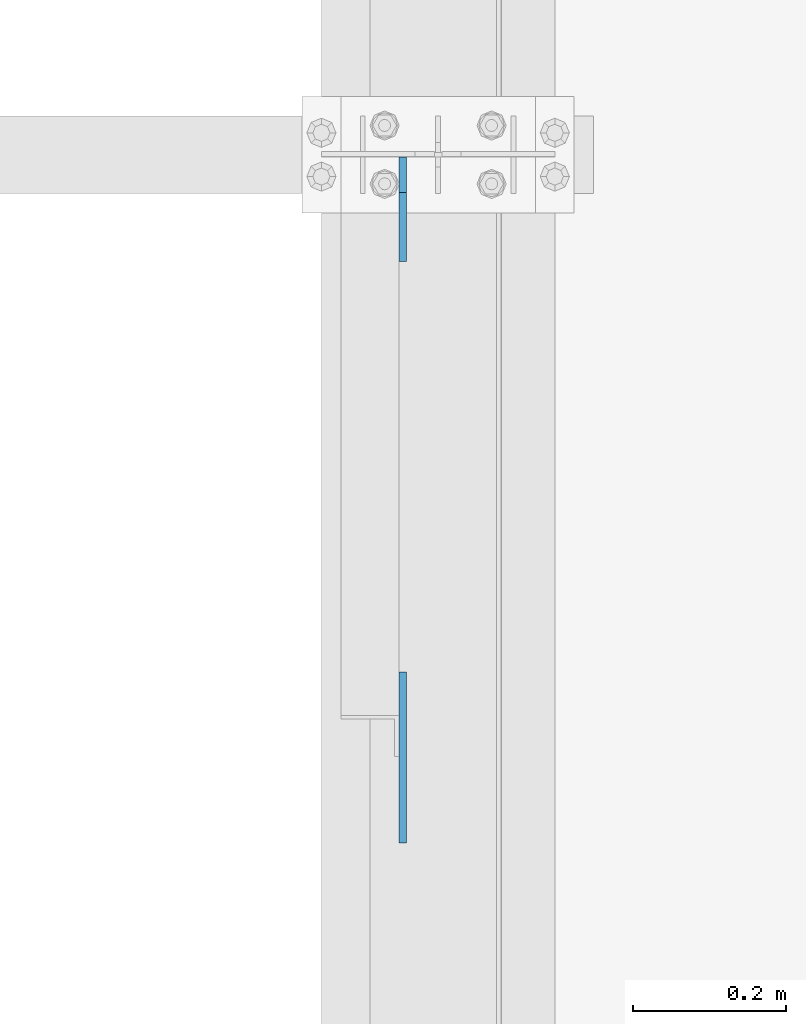
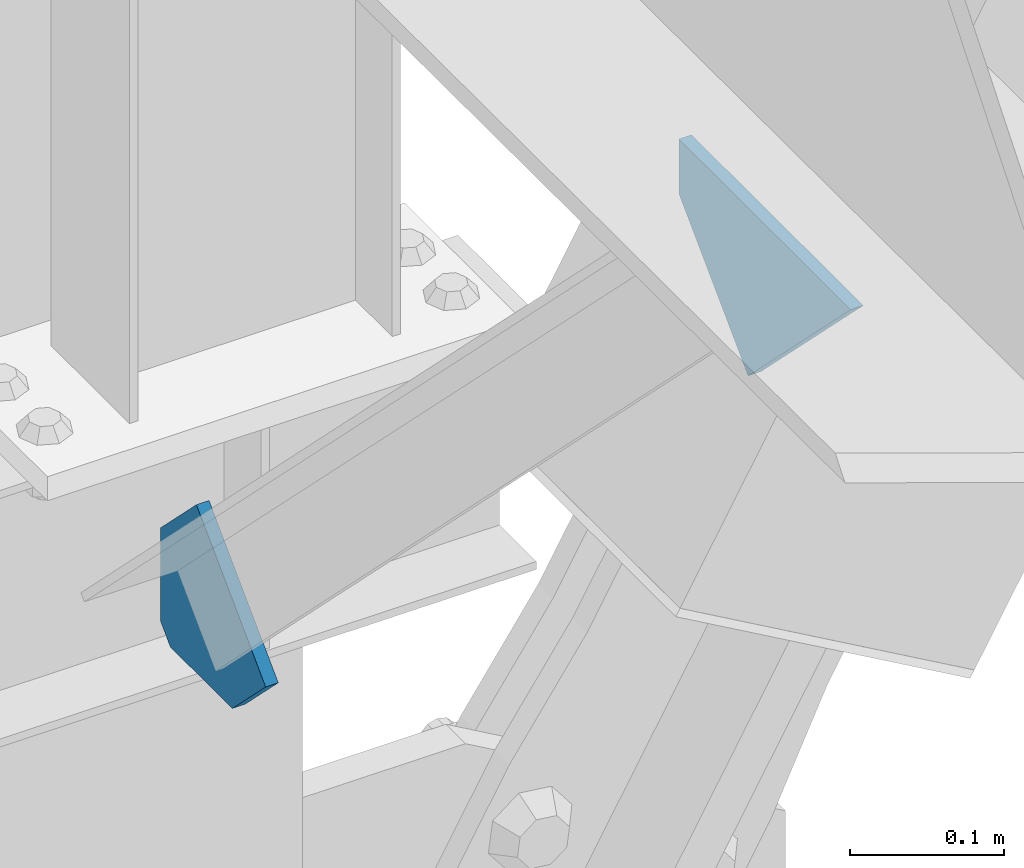
# One storey, part 3378 of 3843: 2 plates, 2 elements without a shape of their own.
"""IFC2X3 building model written with IfcOpenShell, lengths in millimetres."""

import ifcopenshell
import ifcopenshell.guid

model = None  # the IFC model being written
_history = None  # IfcOwnerHistory: only IFC2X3 demands one
_inside = {}  # id of a spatial element -> (the spatial element, [elements in it])
_under = {}  # id of a project, library or spatial element -> (it, [spatial elements below it])
_declared = {}  # id of a project -> (the project, [libraries it declares])
_typed = {}  # id of a type object -> (the type object, [elements of that type])
_made_of = {}  # id of a material, layer set ... -> (it, [elements and type objects made of it])


def new_model(schema):
    """Start an empty IFC model of exactly this schema.

    Asked for "IFC4X3", IfcOpenShell would pick the latest addendum, in which some entities
    have other attributes; the version numbers below select the first issue.
    IFC2X3 requires an IfcOwnerHistory on every rooted entity: one is made here for all.
    """
    global model, _history
    if schema == "IFC4X3":
        model = ifcopenshell.file(schema_version=(4, 3, 0, 0))
    else:
        model = ifcopenshell.file(schema=schema)
    _inside.clear()
    _under.clear()
    _declared.clear()
    _typed.clear()
    _made_of.clear()
    _history = None
    if model.schema == "IFC2X3":
        org = make("IfcOrganization", Name="unknown")
        user = make(
            "IfcPersonAndOrganization",
            ThePerson=make("IfcPerson", FamilyName="unknown"),
            TheOrganization=org,
        )
        app = make(
            "IfcApplication",
            ApplicationDeveloper=org,
            Version="unknown",
            ApplicationFullName="unknown",
            ApplicationIdentifier="unknown",
        )
        _history = make(
            "IfcOwnerHistory",
            OwningUser=user,
            OwningApplication=app,
            ChangeAction="ADDED",
            CreationDate=0,
        )
    return model


def make(cls, **values):
    """One entity of the class cls with the attributes given. An attribute that is None is left unset."""
    return model.create_entity(
        cls, **{name: value for name, value in values.items() if value is not None}
    )


def rooted(cls, **values):
    """An entity with a GlobalId (a new one), such as an element, a storey or a relation."""
    return make(cls, GlobalId=ifcopenshell.guid.new(), OwnerHistory=_history, **values)


def si_unit(unit_type, name, prefix=None):
    """IfcSIUnit, for example si_unit("LENGTHUNIT", "METRE", prefix="MILLI")."""
    return make("IfcSIUnit", UnitType=unit_type, Prefix=prefix, Name=name)


def assignment(units):
    """IfcUnitAssignment: the units of a project."""
    return None if units is None else make("IfcUnitAssignment", Units=units)


def point(xyz):
    """IfcCartesianPoint."""
    return None if xyz is None else make("IfcCartesianPoint", Coordinates=xyz)


def direction(xyz):
    """IfcDirection."""
    return None if xyz is None else make("IfcDirection", DirectionRatios=xyz)


def frame(location, z_axis=None, x_axis=None):
    """IfcAxis2Placement3D, a coordinate frame: its origin and axes. An axis left out is left unset."""
    return make(
        "IfcAxis2Placement3D",
        Location=point(location),
        Axis=direction(z_axis),
        RefDirection=direction(x_axis),
    )


def origin_with_axes():
    """The frame at (0, 0, 0) with the z axis (0, 0, 1) and the x axis (1, 0, 0) written out."""
    return frame((0.0, 0.0, 0.0), z_axis=(0.0, 0.0, 1.0), x_axis=(1.0, 0.0, 0.0))


def place(relative_to, where):
    """IfcLocalPlacement: puts the frame where relative to a parent placement (None: the world)."""
    return make(
        "IfcLocalPlacement", PlacementRelTo=relative_to, RelativePlacement=where
    )


def context(
    kind, dimensions, precision=None, world=None, true_north=None, identifier=None
):
    """IfcGeometricRepresentationContext, for example the 3D "Model" context."""
    return make(
        "IfcGeometricRepresentationContext",
        ContextIdentifier=identifier,
        ContextType=kind,
        CoordinateSpaceDimension=dimensions,
        Precision=precision,
        WorldCoordinateSystem=world,
        TrueNorth=true_north,
    )


def subcontext(parent, identifier, kind, view, scale=None):
    """IfcGeometricRepresentationSubContext, for example "Body" below "Model"."""
    return make(
        "IfcGeometricRepresentationSubContext",
        ContextIdentifier=identifier,
        ContextType=kind,
        ParentContext=parent,
        TargetScale=scale,
        TargetView=view,
    )


def project(units=None, contexts=None):
    """IfcProject with its units and contexts."""
    return rooted(
        "IfcProject",
        Name="project",
        RepresentationContexts=contexts,
        UnitsInContext=assignment(units),
    )


def spatial(cls, under=None, at=None, **own):
    """A site, building, storey or space (cls), placed at a placement, below another one or the project."""
    s = rooted(cls, ObjectPlacement=at, **own)
    if under is not None:
        _under.setdefault(under.id(), (under, []))[1].append(s)
    return s


def faces_of(points, faces, orient=None, outer=None):
    """IfcFace entities. A face is a list of loops; a loop is a list of indices into points, from 0.

    orient and outer hold one flag for each loop. By default every Orientation is true, the
    first loop of a face is its IfcFaceOuterBound and the others are IfcFaceBound.
    """
    made = []
    for i, loops in enumerate(faces):
        bounds = []
        for j, loop in enumerate(loops):
            is_outer = j == 0 if outer is None else outer[i][j]
            bounds.append(
                make(
                    "IfcFaceOuterBound" if is_outer else "IfcFaceBound",
                    Bound=make("IfcPolyLoop", Polygon=[points[k] for k in loop]),
                    Orientation=True if orient is None else orient[i][j],
                )
            )
        made.append(make("IfcFace", Bounds=bounds))
    return made


def faceted_brep(points, faces, orient=None, outer=None, voids=None):
    """IfcFacetedBrep: a solid bounded by flat faces; with voids (closed shells), ...WithVoids."""
    shared = [point(p) for p in points]
    hull = make("IfcClosedShell", CfsFaces=faces_of(shared, faces, orient, outer))
    if voids is None:
        return make("IfcFacetedBrep", Outer=hull)
    return make(
        "IfcFacetedBrepWithVoids",
        Outer=hull,
        Voids=[
            make(cls, CfsFaces=faces_of(shared, fs, o, b)) for cls, fs, o, b in voids
        ],
    )


def shape(context_of_items, identifier, shape_type, items):
    """IfcShapeRepresentation: the items that make up one representation, for example the "Body"."""
    return make(
        "IfcShapeRepresentation",
        ContextOfItems=context_of_items,
        RepresentationIdentifier=identifier,
        RepresentationType=shape_type,
        Items=items,
    )


def material(Name=None, Category=None):
    """IfcMaterial."""
    return make("IfcMaterial", Name=Name, Category=Category)


def made_of(thing, what):
    """Note that an element or type object is made of a material, layer set ...; save() writes the relation."""
    if what is not None:
        _made_of.setdefault(what.id(), (what, []))[1].append(thing)
    return thing


def type_object(cls, material=None, **own):
    """A type object (cls), such as IfcWallType, which elements share."""
    return made_of(rooted(cls, **own), material)


def element(
    cls,
    number,
    at=None,
    inside=None,
    cuts=None,
    type_object=None,
    material=None,
    context=None,
    identifier="Body",
    shape_type=None,
    held_by="IfcProductDefinitionShape",
    body=None,
    shapes=None,
    **own,
):
    """One element of the class cls, such as IfcWall. Its Tag is "e" and its number.

    at: its placement. inside: the storey or other place that contains it. cuts: it is an
    opening in that element (IfcRelVoidsElement). A single representation is given by context,
    identifier, shape_type and body (its items); several are given by shapes. held_by: the class
    of the entity that holds the representations. save() writes the other relations.
    """
    e = rooted(cls, Tag="e%d" % number, ObjectPlacement=at, **own)
    if body is not None:
        shapes = [shape(context, identifier, shape_type, body)]
    if shapes is not None:
        e.Representation = make(held_by, Representations=shapes)
    if inside is not None:
        _inside.setdefault(inside.id(), (inside, []))[1].append(e)
    if cuts is not None:
        rooted(
            "IfcRelVoidsElement", RelatingBuildingElement=cuts, RelatedOpeningElement=e
        )
    if type_object is not None:
        _typed.setdefault(type_object.id(), (type_object, []))[1].append(e)
    return made_of(e, material)


def aggregate(whole, parts):
    """IfcRelAggregates: a whole, such as a stair, and the parts it consists of."""
    return rooted("IfcRelAggregates", RelatingObject=whole, RelatedObjects=parts)


def save(model, path):
    """Write the relations noted so far, then the file.

    IfcRelAggregates (storeys below a building ...), IfcRelContainedInSpatialStructure (elements
    in a storey), IfcRelDefinesByType, IfcRelAssociatesMaterial and IfcRelDeclares: one each for
    every whole, place, type object, material and project.
    """
    for whole, parts in _under.values():
        aggregate(whole, parts)
    for where, things in _inside.values():
        rooted(
            "IfcRelContainedInSpatialStructure",
            RelatedElements=things,
            RelatingStructure=where,
        )
    for kind, things in _typed.values():
        rooted("IfcRelDefinesByType", RelatedObjects=things, RelatingType=kind)
    for what, things in _made_of.values():
        rooted("IfcRelAssociatesMaterial", RelatedObjects=things, RelatingMaterial=what)
    for by, libraries in _declared.values():
        rooted("IfcRelDeclares", RelatingContext=by, RelatedDefinitions=libraries)
    model.write(path)


model = new_model("IFC2X3")

# Units and contexts
model_context = context("Model", 3, precision=1e-05, world=origin_with_axes())
body_context = subcontext(model_context, "Body", "Model", "MODEL_VIEW")
ifc_project = project(units=[si_unit("LENGTHUNIT", "METRE", prefix="MILLI"), si_unit("AREAUNIT", "SQUARE_METRE"), si_unit("VOLUMEUNIT", "CUBIC_METRE"), si_unit("MASSUNIT", "GRAM", prefix="KILO"), si_unit("TIMEUNIT", "SECOND"), si_unit("PLANEANGLEUNIT", "RADIAN"), si_unit("SOLIDANGLEUNIT", "STERADIAN"), si_unit("THERMODYNAMICTEMPERATUREUNIT", "DEGREE_CELSIUS"), si_unit("LUMINOUSINTENSITYUNIT", "LUMEN")], contexts=[model_context])

# Site, building, storey
site_placement = place(None, origin_with_axes())
site = spatial("IfcSite", under=ifc_project, at=site_placement, CompositionType="ELEMENT")
building_placement = place(site_placement, origin_with_axes())
building = spatial("IfcBuilding", under=site, at=building_placement, Name="Undefined", CompositionType="ELEMENT")
storey_placement = place(building_placement, origin_with_axes())
storey = spatial("IfcBuildingStorey", under=building, at=storey_placement, Name="Undefined", CompositionType="ELEMENT", Elevation=0.0)

# Assembly, plate
assembly_1_placement = place(storey_placement, origin_with_axes())
assembly_1 = element("IfcElementAssembly", 1, at=assembly_1_placement, inside=storey, Name="BEAM", AssemblyPlace="NOTDEFINED", PredefinedType="RIGID_FRAME")
ifc_material = material(Name="STEEL/A572-50")
plate_type_1 = type_object("IfcPlateType", PredefinedType="NOTDEFINED")
plate_1_placement = place(assembly_1_placement, frame((42016.3625, 78908.0914419277, 42109.2125354471), z_axis=(0.0, 0.707106781186548, 0.707106781186548), x_axis=(5.70000238222118e-08, 0.707106781186546, -0.707106781186546)))
plate_1 = element("IfcPlate", 2, at=plate_1_placement, type_object=plate_type_1, material=ifc_material, Name="PLATE", context=body_context, shape_type="Brep", body=[
    faceted_brep([(0.0, -4.76249999999709, 0.0), (157.726597423803, -4.76249999999709, 157.726601438866), (157.726597423803, 4.76249999999709, 157.726601438866), (0.0, 4.76249999999709, 0.0), (188.387110059113, -4.76249999999709, 127.066089584019), (188.387110059113, 4.76249999999709, 127.066089584019), (188.387111679331, -4.76249999999709, 1.09139364212751e-10), (188.387111679331, 4.76249999999709, 1.09139364212751e-10)], [[[0, 1, 2, 3]], [[1, 4, 5, 2]], [[4, 6, 7, 5]], [[6, 0, 3, 7]], [[5, 7, 3, 2]], [[6, 4, 1, 0]]]),
])
aggregate(assembly_1, [plate_1])

assembly_2_placement = place(storey_placement, origin_with_axes())
assembly_2 = element("IfcElementAssembly", 3, at=assembly_2_placement, inside=storey, Name="BEAM", AssemblyPlace="NOTDEFINED", PredefinedType="RIGID_FRAME")
plate_type_2 = type_object("IfcPlateType", PredefinedType="NOTDEFINED")
plate_2_placement = place(assembly_2_placement, frame((42016.3625, 79803.625, 41306.75), z_axis=(0.0, -1.0, 0.0), x_axis=(0.0, 0.0, 1.0)))
plate_2 = element("IfcPlate", 4, at=plate_2_placement, type_object=plate_type_2, material=ifc_material, Name="PLATE", context=body_context, shape_type="Brep", body=[
    faceted_brep([(0.0, -4.76250000000073, 12.6999998092651), (4.450703272596e-08, -4.76249999999709, 93.0710244828806), (4.450703272596e-08, 4.76249999999709, 93.0710244828806), (0.0, 4.76250000000073, 12.6999998092651), (43.3137807601452, -4.76249999999709, 136.384805065652), (43.3137807601452, 4.76249999999709, 136.384805065652), (133.209805202001, -4.76249999999709, 46.4887805392646), (133.209805202001, 4.76249999999709, 46.4887805392646), (86.7210245267561, -4.76249999999709, 0.0), (86.7210245267561, 4.76249999999709, 0.0), (12.6999998092651, -4.76250000000073, 0.0), (12.6999998092651, 4.76250000000073, 0.0)], [[[0, 1, 2, 3]], [[1, 4, 5, 2]], [[4, 6, 7, 5]], [[6, 8, 9, 7]], [[8, 10, 11, 9]], [[10, 0, 3, 11]], [[5, 7, 9, 11, 3, 2]], [[10, 8, 6, 4, 1, 0]]]),
])
aggregate(assembly_2, [plate_2])

save(model, "model.ifc")
